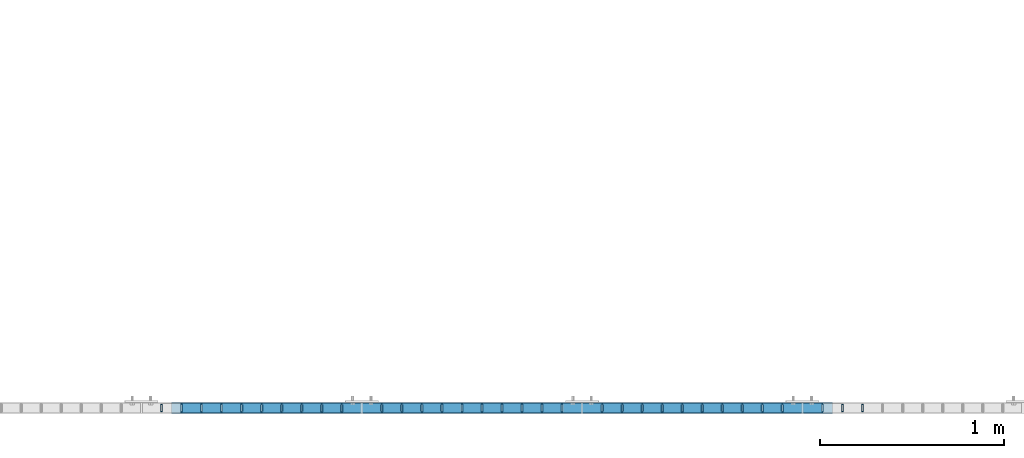
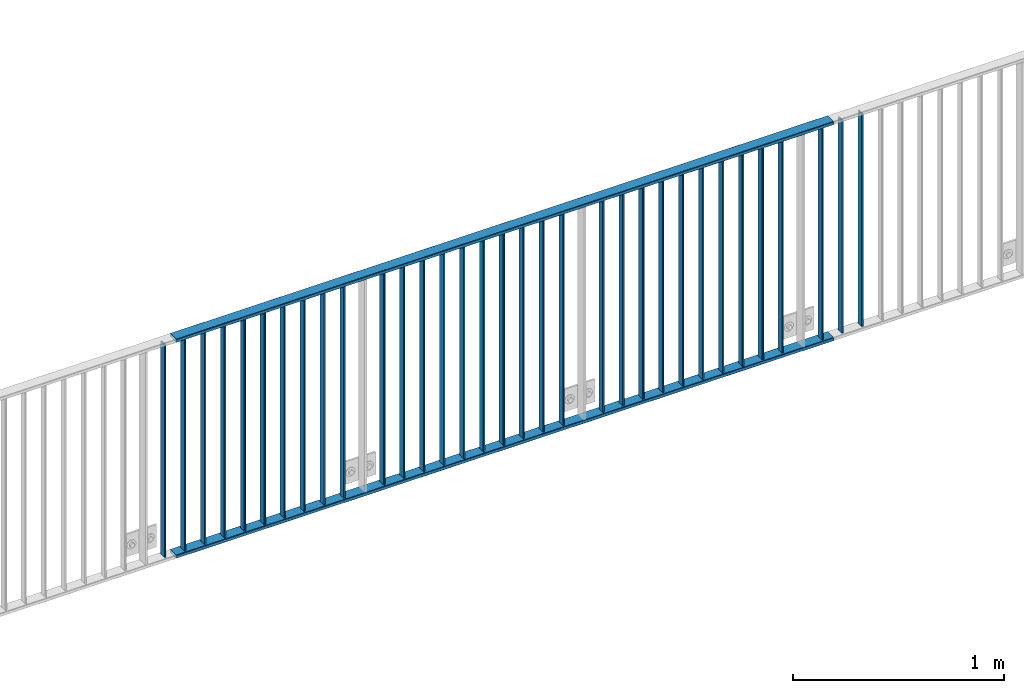
# One storey, part 20 of 156: 35 beams, 3 elements without a shape of their own.
"""IFC2X3 building model written with IfcOpenShell, lengths in millimetres."""

from ifc_helpers import new_model, si_unit, frame, origin_with_axes, origin_2d_with_axis, place, context, subcontext, project, spatial, hollow_rectangle, extrude, clip, halfspace, material, type_object, element, aggregate, save


model = new_model("IFC2X3")

# Units and contexts
model_context = context("Model", 3, precision=1e-05, world=origin_with_axes())
body_context = subcontext(model_context, "Body", "Model", "MODEL_VIEW")
ifc_project = project(units=[si_unit("LENGTHUNIT", "METRE", prefix="MILLI"), si_unit("AREAUNIT", "SQUARE_METRE"), si_unit("VOLUMEUNIT", "CUBIC_METRE"), si_unit("MASSUNIT", "GRAM", prefix="KILO"), si_unit("TIMEUNIT", "SECOND"), si_unit("PLANEANGLEUNIT", "RADIAN"), si_unit("SOLIDANGLEUNIT", "STERADIAN"), si_unit("THERMODYNAMICTEMPERATUREUNIT", "DEGREE_CELSIUS"), si_unit("LUMINOUSINTENSITYUNIT", "LUMEN")], contexts=[model_context])

# Site, building, storey
site_placement = place(None, origin_with_axes())
site = spatial("IfcSite", under=ifc_project, at=site_placement, CompositionType="ELEMENT")
building_placement = place(site_placement, origin_with_axes())
building = spatial("IfcBuilding", under=site, at=building_placement, Name="Undefined", CompositionType="ELEMENT")
storey_placement = place(building_placement, origin_with_axes())
storey = spatial("IfcBuildingStorey", under=building, at=storey_placement, Name="Undefined", CompositionType="ELEMENT", Elevation=0.0)

# Assembly, beams
assembly_1_placement = place(storey_placement, origin_with_axes())
assembly_1 = element("IfcElementAssembly", 1, at=assembly_1_placement, inside=storey, AssemblyPlace="NOTDEFINED", PredefinedType="RIGID_FRAME")
ifc_material = material(Name="STEEL/S235JR")
beam_type_1 = type_object("IfcBeamType", Name="K60/20/2", PredefinedType="NOTDEFINED")
beam_1_placement = place(assembly_1_placement, frame((32363.1399999997, 8480.00209045411, 2740.0), z_axis=(0.0, 1.0, 0.0), x_axis=(1.0, 0.0, 0.0)))
beam_1 = element("IfcBeam", 2, at=beam_1_placement, type_object=beam_type_1, material=ifc_material, ObjectType="K60/20/2", context=body_context, shape_type="SweptSolid", body=[
    extrude(hollow_rectangle(XDim=20.0, YDim=60.0, WallThickness=2.0, InnerFilletRadius=2.0, OuterFilletRadius=4.0, at=origin_2d_with_axis()), frame((3599.89999999999, 0.0, 0.0), z_axis=(-1.0, 0.0, 0.0), x_axis=(0.0, -1.0, 0.0)), (0.0, 0.0, 1.0), 3599.9),
])
beam_2_placement = place(assembly_1_placement, frame((32363.1399999997, 8479.98209032628, 3990.0), z_axis=(0.0, 1.0, 0.0), x_axis=(1.0, 0.0, 0.0)))
beam_2 = element("IfcBeam", 3, at=beam_2_placement, type_object=beam_type_1, material=ifc_material, ObjectType="K60/20/2", context=body_context, shape_type="SweptSolid", body=[
    extrude(hollow_rectangle(XDim=20.0, YDim=60.0, WallThickness=2.0, InnerFilletRadius=2.0, OuterFilletRadius=4.0, at=origin_2d_with_axis()), frame((3599.89999999999, 0.0, 0.0), z_axis=(-1.0, 0.0, 0.0), x_axis=(0.0, -1.0, 0.0)), (0.0, 0.0, 1.0), 3599.9),
])

assembly_2_placement = place(storey_placement, origin_with_axes())
assembly_2 = element("IfcElementAssembly", 4, at=assembly_2_placement, inside=storey, AssemblyPlace="NOTDEFINED", PredefinedType="RIGID_FRAME")
beam_type_2 = type_object("IfcBeamType", Name="K40/10/1.5", PredefinedType="NOTDEFINED")
beam_3_placement = place(assembly_2_placement, frame((36127.269999999, 8480.00209765299, 3980.00000000003), z_axis=(0.0, 1.0, 0.0), x_axis=(0.0, 0.0, -1.0)))
beam_3 = element("IfcBeam", 5, at=beam_3_placement, type_object=beam_type_2, material=ifc_material, ObjectType="K40/10/1.5", context=body_context, shape_type="Clipping", body=[
    clip(extrude(hollow_rectangle(XDim=10.0, YDim=40.0, WallThickness=1.5, InnerFilletRadius=1.5, OuterFilletRadius=3.0, at=origin_2d_with_axis()), frame((1230.0, 0.0, 0.0), z_axis=(-1.0, 0.0, 0.0), x_axis=(0.0, -1.0, 0.0)), (0.0, 0.0, 1.0), 1230.0), halfspace(frame((-6.99999999997453, -4.34248751950508, 47.3810900558092), z_axis=(-1.0, 0.0, 0.0), x_axis=(0.0, 0.7683548141934, -0.640024124159258)), False)),
])
beam_4_placement = place(assembly_2_placement, frame((36018.179999999, 8480.00209765299, 3980.00000000003), z_axis=(0.0, 1.0, 0.0), x_axis=(0.0, 0.0, -1.0)))
beam_4 = element("IfcBeam", 6, at=beam_4_placement, type_object=beam_type_2, material=ifc_material, ObjectType="K40/10/1.5", context=body_context, shape_type="Clipping", body=[
    clip(extrude(hollow_rectangle(XDim=10.0, YDim=40.0, WallThickness=1.5, InnerFilletRadius=1.5, OuterFilletRadius=3.0, at=origin_2d_with_axis()), frame((1230.0, 0.0, 0.0), z_axis=(-1.0, 0.0, 0.0), x_axis=(0.0, -1.0, 0.0)), (0.0, 0.0, 1.0), 1230.0), halfspace(frame((-6.99999999997453, -4.34248751950508, 47.3810900558092), z_axis=(-1.0, 0.0, 0.0), x_axis=(0.0, 0.7683548141934, -0.640024124159258)), False)),
])
aggregate(assembly_2, [beam_3, beam_4])

# Beam
beam_5_placement = place(assembly_1_placement, frame((35909.089999999, 8480.00209765299, 3980.00000000003), z_axis=(0.0, 1.0, 0.0), x_axis=(0.0, 0.0, -1.0)))
beam_5 = element("IfcBeam", 7, at=beam_5_placement, type_object=beam_type_2, material=ifc_material, ObjectType="K40/10/1.5", context=body_context, shape_type="Clipping", body=[
    clip(extrude(hollow_rectangle(XDim=10.0, YDim=40.0, WallThickness=1.5, InnerFilletRadius=1.5, OuterFilletRadius=3.0, at=origin_2d_with_axis()), frame((1230.0, 0.0, 0.0), z_axis=(-1.0, 0.0, 0.0), x_axis=(0.0, -1.0, 0.0)), (0.0, 0.0, 1.0), 1230.0), halfspace(frame((-6.99999999997453, -4.34248751950508, 47.3810900558092), z_axis=(-1.0, 0.0, 0.0), x_axis=(0.0, 0.7683548141934, -0.640024124159258)), False)),
])

beam_6_placement = place(assembly_1_placement, frame((35690.899999999, 8480.00209765299, 3980.00000000003), z_axis=(0.0, 1.0, 0.0), x_axis=(0.0, 0.0, -1.0)))
beam_6 = element("IfcBeam", 8, at=beam_6_placement, type_object=beam_type_2, material=ifc_material, ObjectType="K40/10/1.5", context=body_context, shape_type="Clipping", body=[
    clip(extrude(hollow_rectangle(XDim=10.0, YDim=40.0, WallThickness=1.5, InnerFilletRadius=1.5, OuterFilletRadius=3.0, at=origin_2d_with_axis()), frame((1230.0, 0.0, 0.0), z_axis=(-1.0, 0.0, 0.0), x_axis=(0.0, -1.0, 0.0)), (0.0, 0.0, 1.0), 1230.0), halfspace(frame((-6.99999999997453, -4.34248751950508, 47.3810900558092), z_axis=(-1.0, 0.0, 0.0), x_axis=(0.0, 0.7683548141934, -0.640024124159258)), False)),
])

beam_7_placement = place(assembly_1_placement, frame((35581.809999999, 8480.00209765299, 3980.00000000003), z_axis=(0.0, 1.0, 0.0), x_axis=(0.0, 0.0, -1.0)))
beam_7 = element("IfcBeam", 9, at=beam_7_placement, type_object=beam_type_2, material=ifc_material, ObjectType="K40/10/1.5", context=body_context, shape_type="Clipping", body=[
    clip(extrude(hollow_rectangle(XDim=10.0, YDim=40.0, WallThickness=1.5, InnerFilletRadius=1.5, OuterFilletRadius=3.0, at=origin_2d_with_axis()), frame((1230.0, 0.0, 0.0), z_axis=(-1.0, 0.0, 0.0), x_axis=(0.0, -1.0, 0.0)), (0.0, 0.0, 1.0), 1230.0), halfspace(frame((-6.99999999997453, -4.34248751950508, 47.3810900558092), z_axis=(-1.0, 0.0, 0.0), x_axis=(0.0, 0.7683548141934, -0.640024124159258)), False)),
])

beam_8_placement = place(assembly_1_placement, frame((35472.719999999, 8480.00209765299, 3980.00000000003), z_axis=(0.0, 1.0, 0.0), x_axis=(0.0, 0.0, -1.0)))
beam_8 = element("IfcBeam", 10, at=beam_8_placement, type_object=beam_type_2, material=ifc_material, ObjectType="K40/10/1.5", context=body_context, shape_type="Clipping", body=[
    clip(extrude(hollow_rectangle(XDim=10.0, YDim=40.0, WallThickness=1.5, InnerFilletRadius=1.5, OuterFilletRadius=3.0, at=origin_2d_with_axis()), frame((1230.0, 0.0, 0.0), z_axis=(-1.0, 0.0, 0.0), x_axis=(0.0, -1.0, 0.0)), (0.0, 0.0, 1.0), 1230.0), halfspace(frame((-6.99999999997453, -4.34248751950508, 47.3810900558092), z_axis=(-1.0, 0.0, 0.0), x_axis=(0.0, 0.7683548141934, -0.640024124159258)), False)),
])

beam_9_placement = place(assembly_1_placement, frame((35363.629999999, 8480.00209765299, 3980.00000000003), z_axis=(0.0, 1.0, 0.0), x_axis=(0.0, 0.0, -1.0)))
beam_9 = element("IfcBeam", 11, at=beam_9_placement, type_object=beam_type_2, material=ifc_material, ObjectType="K40/10/1.5", context=body_context, shape_type="Clipping", body=[
    clip(extrude(hollow_rectangle(XDim=10.0, YDim=40.0, WallThickness=1.5, InnerFilletRadius=1.5, OuterFilletRadius=3.0, at=origin_2d_with_axis()), frame((1230.0, 0.0, 0.0), z_axis=(-1.0, 0.0, 0.0), x_axis=(0.0, -1.0, 0.0)), (0.0, 0.0, 1.0), 1230.0), halfspace(frame((-6.99999999997453, -4.34248751950508, 47.3810900558092), z_axis=(-1.0, 0.0, 0.0), x_axis=(0.0, 0.7683548141934, -0.640024124159258)), False)),
])

beam_10_placement = place(assembly_1_placement, frame((35254.539999999, 8480.00209765299, 3980.00000000003), z_axis=(0.0, 1.0, 0.0), x_axis=(0.0, 0.0, -1.0)))
beam_10 = element("IfcBeam", 12, at=beam_10_placement, type_object=beam_type_2, material=ifc_material, ObjectType="K40/10/1.5", context=body_context, shape_type="Clipping", body=[
    clip(extrude(hollow_rectangle(XDim=10.0, YDim=40.0, WallThickness=1.5, InnerFilletRadius=1.5, OuterFilletRadius=3.0, at=origin_2d_with_axis()), frame((1230.0, 0.0, 0.0), z_axis=(-1.0, 0.0, 0.0), x_axis=(0.0, -1.0, 0.0)), (0.0, 0.0, 1.0), 1230.0), halfspace(frame((-6.99999999997453, -4.34248751950508, 47.3810900558092), z_axis=(-1.0, 0.0, 0.0), x_axis=(0.0, 0.7683548141934, -0.640024124159258)), False)),
])

beam_11_placement = place(assembly_1_placement, frame((35145.449999999, 8480.00209765299, 3980.00000000003), z_axis=(0.0, 1.0, 0.0), x_axis=(0.0, 0.0, -1.0)))
beam_11 = element("IfcBeam", 13, at=beam_11_placement, type_object=beam_type_2, material=ifc_material, ObjectType="K40/10/1.5", context=body_context, shape_type="Clipping", body=[
    clip(extrude(hollow_rectangle(XDim=10.0, YDim=40.0, WallThickness=1.5, InnerFilletRadius=1.5, OuterFilletRadius=3.0, at=origin_2d_with_axis()), frame((1230.0, 0.0, 0.0), z_axis=(-1.0, 0.0, 0.0), x_axis=(0.0, -1.0, 0.0)), (0.0, 0.0, 1.0), 1230.0), halfspace(frame((-6.99999999997453, -4.34248751950508, 47.3810900558092), z_axis=(-1.0, 0.0, 0.0), x_axis=(0.0, 0.7683548141934, -0.640024124159258)), False)),
])

beam_12_placement = place(assembly_1_placement, frame((35036.359999999, 8480.00209765299, 3980.00000000003), z_axis=(0.0, 1.0, 0.0), x_axis=(0.0, 0.0, -1.0)))
beam_12 = element("IfcBeam", 14, at=beam_12_placement, type_object=beam_type_2, material=ifc_material, ObjectType="K40/10/1.5", context=body_context, shape_type="Clipping", body=[
    clip(extrude(hollow_rectangle(XDim=10.0, YDim=40.0, WallThickness=1.5, InnerFilletRadius=1.5, OuterFilletRadius=3.0, at=origin_2d_with_axis()), frame((1230.0, 0.0, 0.0), z_axis=(-1.0, 0.0, 0.0), x_axis=(0.0, -1.0, 0.0)), (0.0, 0.0, 1.0), 1230.0), halfspace(frame((-6.99999999997453, -4.34248751950508, 47.3810900558092), z_axis=(-1.0, 0.0, 0.0), x_axis=(0.0, 0.7683548141934, -0.640024124159258)), False)),
])

beam_13_placement = place(assembly_1_placement, frame((34927.269999999, 8480.00209765299, 3980.00000000003), z_axis=(0.0, 1.0, 0.0), x_axis=(0.0, 0.0, -1.0)))
beam_13 = element("IfcBeam", 15, at=beam_13_placement, type_object=beam_type_2, material=ifc_material, ObjectType="K40/10/1.5", context=body_context, shape_type="Clipping", body=[
    clip(extrude(hollow_rectangle(XDim=10.0, YDim=40.0, WallThickness=1.5, InnerFilletRadius=1.5, OuterFilletRadius=3.0, at=origin_2d_with_axis()), frame((1230.0, 0.0, 0.0), z_axis=(-1.0, 0.0, 0.0), x_axis=(0.0, -1.0, 0.0)), (0.0, 0.0, 1.0), 1230.0), halfspace(frame((-6.99999999997453, -4.34248751950508, 47.3810900558092), z_axis=(-1.0, 0.0, 0.0), x_axis=(0.0, 0.7683548141934, -0.640024124159258)), False)),
])

beam_14_placement = place(assembly_1_placement, frame((34818.179999999, 8480.00209765299, 3980.00000000003), z_axis=(0.0, 1.0, 0.0), x_axis=(0.0, 0.0, -1.0)))
beam_14 = element("IfcBeam", 16, at=beam_14_placement, type_object=beam_type_2, material=ifc_material, ObjectType="K40/10/1.5", context=body_context, shape_type="Clipping", body=[
    clip(extrude(hollow_rectangle(XDim=10.0, YDim=40.0, WallThickness=1.5, InnerFilletRadius=1.5, OuterFilletRadius=3.0, at=origin_2d_with_axis()), frame((1230.0, 0.0, 0.0), z_axis=(-1.0, 0.0, 0.0), x_axis=(0.0, -1.0, 0.0)), (0.0, 0.0, 1.0), 1230.0), halfspace(frame((-6.99999999997453, -4.34248751950508, 47.3810900558092), z_axis=(-1.0, 0.0, 0.0), x_axis=(0.0, 0.7683548141934, -0.640024124159258)), False)),
])

beam_15_placement = place(assembly_1_placement, frame((34709.089999999, 8480.00209765299, 3980.00000000003), z_axis=(0.0, 1.0, 0.0), x_axis=(0.0, 0.0, -1.0)))
beam_15 = element("IfcBeam", 17, at=beam_15_placement, type_object=beam_type_2, material=ifc_material, ObjectType="K40/10/1.5", context=body_context, shape_type="Clipping", body=[
    clip(extrude(hollow_rectangle(XDim=10.0, YDim=40.0, WallThickness=1.5, InnerFilletRadius=1.5, OuterFilletRadius=3.0, at=origin_2d_with_axis()), frame((1230.0, 0.0, 0.0), z_axis=(-1.0, 0.0, 0.0), x_axis=(0.0, -1.0, 0.0)), (0.0, 0.0, 1.0), 1230.0), halfspace(frame((-6.99999999997453, -4.34248751950508, 47.3810900558092), z_axis=(-1.0, 0.0, 0.0), x_axis=(0.0, 0.7683548141934, -0.640024124159258)), False)),
])

beam_16_placement = place(assembly_1_placement, frame((34490.899999999, 8480.00209765299, 3980.00000000003), z_axis=(0.0, 1.0, 0.0), x_axis=(0.0, 0.0, -1.0)))
beam_16 = element("IfcBeam", 18, at=beam_16_placement, type_object=beam_type_2, material=ifc_material, ObjectType="K40/10/1.5", context=body_context, shape_type="Clipping", body=[
    clip(extrude(hollow_rectangle(XDim=10.0, YDim=40.0, WallThickness=1.5, InnerFilletRadius=1.5, OuterFilletRadius=3.0, at=origin_2d_with_axis()), frame((1230.0, 0.0, 0.0), z_axis=(-1.0, 0.0, 0.0), x_axis=(0.0, -1.0, 0.0)), (0.0, 0.0, 1.0), 1230.0), halfspace(frame((-6.99999999997453, -4.34248751950508, 47.3810900558092), z_axis=(-1.0, 0.0, 0.0), x_axis=(0.0, 0.7683548141934, -0.640024124159258)), False)),
])

beam_17_placement = place(assembly_1_placement, frame((34381.809999999, 8480.00209765299, 3980.00000000003), z_axis=(0.0, 1.0, 0.0), x_axis=(0.0, 0.0, -1.0)))
beam_17 = element("IfcBeam", 19, at=beam_17_placement, type_object=beam_type_2, material=ifc_material, ObjectType="K40/10/1.5", context=body_context, shape_type="Clipping", body=[
    clip(extrude(hollow_rectangle(XDim=10.0, YDim=40.0, WallThickness=1.5, InnerFilletRadius=1.5, OuterFilletRadius=3.0, at=origin_2d_with_axis()), frame((1230.0, 0.0, 0.0), z_axis=(-1.0, 0.0, 0.0), x_axis=(0.0, -1.0, 0.0)), (0.0, 0.0, 1.0), 1230.0), halfspace(frame((-6.99999999997453, -4.34248751950508, 47.3810900558092), z_axis=(-1.0, 0.0, 0.0), x_axis=(0.0, 0.7683548141934, -0.640024124159258)), False)),
])

beam_18_placement = place(assembly_1_placement, frame((34272.719999999, 8480.00209765299, 3980.00000000003), z_axis=(0.0, 1.0, 0.0), x_axis=(0.0, 0.0, -1.0)))
beam_18 = element("IfcBeam", 20, at=beam_18_placement, type_object=beam_type_2, material=ifc_material, ObjectType="K40/10/1.5", context=body_context, shape_type="Clipping", body=[
    clip(extrude(hollow_rectangle(XDim=10.0, YDim=40.0, WallThickness=1.5, InnerFilletRadius=1.5, OuterFilletRadius=3.0, at=origin_2d_with_axis()), frame((1230.0, 0.0, 0.0), z_axis=(-1.0, 0.0, 0.0), x_axis=(0.0, -1.0, 0.0)), (0.0, 0.0, 1.0), 1230.0), halfspace(frame((-6.99999999997453, -4.34248751950508, 47.3810900558092), z_axis=(-1.0, 0.0, 0.0), x_axis=(0.0, 0.7683548141934, -0.640024124159258)), False)),
])

beam_19_placement = place(assembly_1_placement, frame((34163.629999999, 8480.00209765299, 3980.00000000003), z_axis=(0.0, 1.0, 0.0), x_axis=(0.0, 0.0, -1.0)))
beam_19 = element("IfcBeam", 21, at=beam_19_placement, type_object=beam_type_2, material=ifc_material, ObjectType="K40/10/1.5", context=body_context, shape_type="Clipping", body=[
    clip(extrude(hollow_rectangle(XDim=10.0, YDim=40.0, WallThickness=1.5, InnerFilletRadius=1.5, OuterFilletRadius=3.0, at=origin_2d_with_axis()), frame((1230.0, 0.0, 0.0), z_axis=(-1.0, 0.0, 0.0), x_axis=(0.0, -1.0, 0.0)), (0.0, 0.0, 1.0), 1230.0), halfspace(frame((-6.99999999997453, -4.34248751950508, 47.3810900558092), z_axis=(-1.0, 0.0, 0.0), x_axis=(0.0, 0.7683548141934, -0.640024124159258)), False)),
])

beam_20_placement = place(assembly_1_placement, frame((34054.539999999, 8480.00209765299, 3980.00000000003), z_axis=(0.0, 1.0, 0.0), x_axis=(0.0, 0.0, -1.0)))
beam_20 = element("IfcBeam", 22, at=beam_20_placement, type_object=beam_type_2, material=ifc_material, ObjectType="K40/10/1.5", context=body_context, shape_type="Clipping", body=[
    clip(extrude(hollow_rectangle(XDim=10.0, YDim=40.0, WallThickness=1.5, InnerFilletRadius=1.5, OuterFilletRadius=3.0, at=origin_2d_with_axis()), frame((1230.0, 0.0, 0.0), z_axis=(-1.0, 0.0, 0.0), x_axis=(0.0, -1.0, 0.0)), (0.0, 0.0, 1.0), 1230.0), halfspace(frame((-6.99999999997453, -4.34248751950508, 47.3810900558092), z_axis=(-1.0, 0.0, 0.0), x_axis=(0.0, 0.7683548141934, -0.640024124159258)), False)),
])

beam_21_placement = place(assembly_1_placement, frame((33945.449999999, 8480.00209765299, 3980.00000000003), z_axis=(0.0, 1.0, 0.0), x_axis=(0.0, 0.0, -1.0)))
beam_21 = element("IfcBeam", 23, at=beam_21_placement, type_object=beam_type_2, material=ifc_material, ObjectType="K40/10/1.5", context=body_context, shape_type="Clipping", body=[
    clip(extrude(hollow_rectangle(XDim=10.0, YDim=40.0, WallThickness=1.5, InnerFilletRadius=1.5, OuterFilletRadius=3.0, at=origin_2d_with_axis()), frame((1230.0, 0.0, 0.0), z_axis=(-1.0, 0.0, 0.0), x_axis=(0.0, -1.0, 0.0)), (0.0, 0.0, 1.0), 1230.0), halfspace(frame((-6.99999999997453, -4.34248751950508, 47.3810900558092), z_axis=(-1.0, 0.0, 0.0), x_axis=(0.0, 0.7683548141934, -0.640024124159258)), False)),
])

beam_22_placement = place(assembly_1_placement, frame((33836.359999999, 8480.00209765299, 3980.00000000003), z_axis=(0.0, 1.0, 0.0), x_axis=(0.0, 0.0, -1.0)))
beam_22 = element("IfcBeam", 24, at=beam_22_placement, type_object=beam_type_2, material=ifc_material, ObjectType="K40/10/1.5", context=body_context, shape_type="Clipping", body=[
    clip(extrude(hollow_rectangle(XDim=10.0, YDim=40.0, WallThickness=1.5, InnerFilletRadius=1.5, OuterFilletRadius=3.0, at=origin_2d_with_axis()), frame((1230.0, 0.0, 0.0), z_axis=(-1.0, 0.0, 0.0), x_axis=(0.0, -1.0, 0.0)), (0.0, 0.0, 1.0), 1230.0), halfspace(frame((-6.99999999997453, -4.34248751950508, 47.3810900558092), z_axis=(-1.0, 0.0, 0.0), x_axis=(0.0, 0.7683548141934, -0.640024124159258)), False)),
])

beam_23_placement = place(assembly_1_placement, frame((33727.269999999, 8480.00209765299, 3980.00000000003), z_axis=(0.0, 1.0, 0.0), x_axis=(0.0, 0.0, -1.0)))
beam_23 = element("IfcBeam", 25, at=beam_23_placement, type_object=beam_type_2, material=ifc_material, ObjectType="K40/10/1.5", context=body_context, shape_type="Clipping", body=[
    clip(extrude(hollow_rectangle(XDim=10.0, YDim=40.0, WallThickness=1.5, InnerFilletRadius=1.5, OuterFilletRadius=3.0, at=origin_2d_with_axis()), frame((1230.0, 0.0, 0.0), z_axis=(-1.0, 0.0, 0.0), x_axis=(0.0, -1.0, 0.0)), (0.0, 0.0, 1.0), 1230.0), halfspace(frame((-6.99999999997453, -4.34248751950508, 47.3810900558092), z_axis=(-1.0, 0.0, 0.0), x_axis=(0.0, 0.7683548141934, -0.640024124159258)), False)),
])

beam_24_placement = place(assembly_1_placement, frame((33618.179999999, 8480.00209765299, 3980.00000000003), z_axis=(0.0, 1.0, 0.0), x_axis=(0.0, 0.0, -1.0)))
beam_24 = element("IfcBeam", 26, at=beam_24_placement, type_object=beam_type_2, material=ifc_material, ObjectType="K40/10/1.5", context=body_context, shape_type="Clipping", body=[
    clip(extrude(hollow_rectangle(XDim=10.0, YDim=40.0, WallThickness=1.5, InnerFilletRadius=1.5, OuterFilletRadius=3.0, at=origin_2d_with_axis()), frame((1230.0, 0.0, 0.0), z_axis=(-1.0, 0.0, 0.0), x_axis=(0.0, -1.0, 0.0)), (0.0, 0.0, 1.0), 1230.0), halfspace(frame((-6.99999999997453, -4.34248751950508, 47.3810900558092), z_axis=(-1.0, 0.0, 0.0), x_axis=(0.0, 0.7683548141934, -0.640024124159258)), False)),
])

beam_25_placement = place(assembly_1_placement, frame((33509.089999999, 8480.00209765299, 3980.00000000003), z_axis=(0.0, 1.0, 0.0), x_axis=(0.0, 0.0, -1.0)))
beam_25 = element("IfcBeam", 27, at=beam_25_placement, type_object=beam_type_2, material=ifc_material, ObjectType="K40/10/1.5", context=body_context, shape_type="Clipping", body=[
    clip(extrude(hollow_rectangle(XDim=10.0, YDim=40.0, WallThickness=1.5, InnerFilletRadius=1.5, OuterFilletRadius=3.0, at=origin_2d_with_axis()), frame((1230.0, 0.0, 0.0), z_axis=(-1.0, 0.0, 0.0), x_axis=(0.0, -1.0, 0.0)), (0.0, 0.0, 1.0), 1230.0), halfspace(frame((-6.99999999997453, -4.34248751950508, 47.3810900558092), z_axis=(-1.0, 0.0, 0.0), x_axis=(0.0, 0.7683548141934, -0.640024124159258)), False)),
])

beam_26_placement = place(assembly_1_placement, frame((33290.899999999, 8480.00209765299, 3980.00000000003), z_axis=(0.0, 1.0, 0.0), x_axis=(0.0, 0.0, -1.0)))
beam_26 = element("IfcBeam", 28, at=beam_26_placement, type_object=beam_type_2, material=ifc_material, ObjectType="K40/10/1.5", context=body_context, shape_type="Clipping", body=[
    clip(extrude(hollow_rectangle(XDim=10.0, YDim=40.0, WallThickness=1.5, InnerFilletRadius=1.5, OuterFilletRadius=3.0, at=origin_2d_with_axis()), frame((1230.0, 0.0, 0.0), z_axis=(-1.0, 0.0, 0.0), x_axis=(0.0, -1.0, 0.0)), (0.0, 0.0, 1.0), 1230.0), halfspace(frame((-6.99999999997453, -4.34248751950508, 47.3810900558092), z_axis=(-1.0, 0.0, 0.0), x_axis=(0.0, 0.7683548141934, -0.640024124159258)), False)),
])

beam_27_placement = place(assembly_1_placement, frame((33181.809999999, 8480.00209765299, 3980.00000000003), z_axis=(0.0, 1.0, 0.0), x_axis=(0.0, 0.0, -1.0)))
beam_27 = element("IfcBeam", 29, at=beam_27_placement, type_object=beam_type_2, material=ifc_material, ObjectType="K40/10/1.5", context=body_context, shape_type="Clipping", body=[
    clip(extrude(hollow_rectangle(XDim=10.0, YDim=40.0, WallThickness=1.5, InnerFilletRadius=1.5, OuterFilletRadius=3.0, at=origin_2d_with_axis()), frame((1230.0, 0.0, 0.0), z_axis=(-1.0, 0.0, 0.0), x_axis=(0.0, -1.0, 0.0)), (0.0, 0.0, 1.0), 1230.0), halfspace(frame((-6.99999999997453, -4.34248751950508, 47.3810900558092), z_axis=(-1.0, 0.0, 0.0), x_axis=(0.0, 0.7683548141934, -0.640024124159258)), False)),
])

beam_28_placement = place(assembly_1_placement, frame((33072.719999999, 8480.00209765299, 3980.00000000003), z_axis=(0.0, 1.0, 0.0), x_axis=(0.0, 0.0, -1.0)))
beam_28 = element("IfcBeam", 30, at=beam_28_placement, type_object=beam_type_2, material=ifc_material, ObjectType="K40/10/1.5", context=body_context, shape_type="Clipping", body=[
    clip(extrude(hollow_rectangle(XDim=10.0, YDim=40.0, WallThickness=1.5, InnerFilletRadius=1.5, OuterFilletRadius=3.0, at=origin_2d_with_axis()), frame((1230.0, 0.0, 0.0), z_axis=(-1.0, 0.0, 0.0), x_axis=(0.0, -1.0, 0.0)), (0.0, 0.0, 1.0), 1230.0), halfspace(frame((-6.99999999997453, -4.34248751950508, 47.3810900558092), z_axis=(-1.0, 0.0, 0.0), x_axis=(0.0, 0.7683548141934, -0.640024124159258)), False)),
])

beam_29_placement = place(assembly_1_placement, frame((32963.629999999, 8480.00209765299, 3980.00000000003), z_axis=(0.0, 1.0, 0.0), x_axis=(0.0, 0.0, -1.0)))
beam_29 = element("IfcBeam", 31, at=beam_29_placement, type_object=beam_type_2, material=ifc_material, ObjectType="K40/10/1.5", context=body_context, shape_type="Clipping", body=[
    clip(extrude(hollow_rectangle(XDim=10.0, YDim=40.0, WallThickness=1.5, InnerFilletRadius=1.5, OuterFilletRadius=3.0, at=origin_2d_with_axis()), frame((1230.0, 0.0, 0.0), z_axis=(-1.0, 0.0, 0.0), x_axis=(0.0, -1.0, 0.0)), (0.0, 0.0, 1.0), 1230.0), halfspace(frame((-6.99999999997453, -4.34248751950508, 47.3810900558092), z_axis=(-1.0, 0.0, 0.0), x_axis=(0.0, 0.7683548141934, -0.640024124159258)), False)),
])

beam_30_placement = place(assembly_1_placement, frame((32854.539999999, 8480.00209765299, 3980.00000000003), z_axis=(0.0, 1.0, 0.0), x_axis=(0.0, 0.0, -1.0)))
beam_30 = element("IfcBeam", 32, at=beam_30_placement, type_object=beam_type_2, material=ifc_material, ObjectType="K40/10/1.5", context=body_context, shape_type="Clipping", body=[
    clip(extrude(hollow_rectangle(XDim=10.0, YDim=40.0, WallThickness=1.5, InnerFilletRadius=1.5, OuterFilletRadius=3.0, at=origin_2d_with_axis()), frame((1230.0, 0.0, 0.0), z_axis=(-1.0, 0.0, 0.0), x_axis=(0.0, -1.0, 0.0)), (0.0, 0.0, 1.0), 1230.0), halfspace(frame((-6.99999999997453, -4.34248751950508, 47.3810900558092), z_axis=(-1.0, 0.0, 0.0), x_axis=(0.0, 0.7683548141934, -0.640024124159258)), False)),
])

beam_31_placement = place(assembly_1_placement, frame((32745.449999999, 8480.00209765299, 3980.00000000003), z_axis=(0.0, 1.0, 0.0), x_axis=(0.0, 0.0, -1.0)))
beam_31 = element("IfcBeam", 33, at=beam_31_placement, type_object=beam_type_2, material=ifc_material, ObjectType="K40/10/1.5", context=body_context, shape_type="Clipping", body=[
    clip(extrude(hollow_rectangle(XDim=10.0, YDim=40.0, WallThickness=1.5, InnerFilletRadius=1.5, OuterFilletRadius=3.0, at=origin_2d_with_axis()), frame((1230.0, 0.0, 0.0), z_axis=(-1.0, 0.0, 0.0), x_axis=(0.0, -1.0, 0.0)), (0.0, 0.0, 1.0), 1230.0), halfspace(frame((-6.99999999997453, -4.34248751950508, 47.3810900558092), z_axis=(-1.0, 0.0, 0.0), x_axis=(0.0, 0.7683548141934, -0.640024124159258)), False)),
])

beam_32_placement = place(assembly_1_placement, frame((32636.359999999, 8480.00209765299, 3980.00000000003), z_axis=(0.0, 1.0, 0.0), x_axis=(0.0, 0.0, -1.0)))
beam_32 = element("IfcBeam", 34, at=beam_32_placement, type_object=beam_type_2, material=ifc_material, ObjectType="K40/10/1.5", context=body_context, shape_type="Clipping", body=[
    clip(extrude(hollow_rectangle(XDim=10.0, YDim=40.0, WallThickness=1.5, InnerFilletRadius=1.5, OuterFilletRadius=3.0, at=origin_2d_with_axis()), frame((1230.0, 0.0, 0.0), z_axis=(-1.0, 0.0, 0.0), x_axis=(0.0, -1.0, 0.0)), (0.0, 0.0, 1.0), 1230.0), halfspace(frame((-6.99999999997453, -4.34248751950508, 47.3810900558092), z_axis=(-1.0, 0.0, 0.0), x_axis=(0.0, 0.7683548141934, -0.640024124159258)), False)),
])

beam_33_placement = place(assembly_1_placement, frame((32527.269999999, 8480.00209765299, 3980.00000000003), z_axis=(0.0, 1.0, 0.0), x_axis=(0.0, 0.0, -1.0)))
beam_33 = element("IfcBeam", 35, at=beam_33_placement, type_object=beam_type_2, material=ifc_material, ObjectType="K40/10/1.5", context=body_context, shape_type="Clipping", body=[
    clip(extrude(hollow_rectangle(XDim=10.0, YDim=40.0, WallThickness=1.5, InnerFilletRadius=1.5, OuterFilletRadius=3.0, at=origin_2d_with_axis()), frame((1230.0, 0.0, 0.0), z_axis=(-1.0, 0.0, 0.0), x_axis=(0.0, -1.0, 0.0)), (0.0, 0.0, 1.0), 1230.0), halfspace(frame((-6.99999999997453, -4.34248751950508, 47.3810900558092), z_axis=(-1.0, 0.0, 0.0), x_axis=(0.0, 0.7683548141934, -0.640024124159258)), False)),
])

beam_34_placement = place(assembly_1_placement, frame((32418.179999999, 8480.00209765299, 3980.00000000003), z_axis=(0.0, 1.0, 0.0), x_axis=(0.0, 0.0, -1.0)))
beam_34 = element("IfcBeam", 36, at=beam_34_placement, type_object=beam_type_2, material=ifc_material, ObjectType="K40/10/1.5", context=body_context, shape_type="Clipping", body=[
    clip(extrude(hollow_rectangle(XDim=10.0, YDim=40.0, WallThickness=1.5, InnerFilletRadius=1.5, OuterFilletRadius=3.0, at=origin_2d_with_axis()), frame((1230.0, 0.0, 0.0), z_axis=(-1.0, 0.0, 0.0), x_axis=(0.0, -1.0, 0.0)), (0.0, 0.0, 1.0), 1230.0), halfspace(frame((-6.99999999997453, -4.34248751950508, 47.3810900558092), z_axis=(-1.0, 0.0, 0.0), x_axis=(0.0, 0.7683548141934, -0.640024124159258)), False)),
])

aggregate(assembly_1, [beam_1, beam_2, beam_5, beam_6, beam_7, beam_8, beam_9, beam_10, beam_11, beam_12, beam_13, beam_14, beam_15, beam_16, beam_17, beam_18, beam_19, beam_20, beam_21, beam_22, beam_23, beam_24, beam_25, beam_26, beam_27, beam_28, beam_29, beam_30, beam_31, beam_32, beam_33, beam_34])

# Assembly, beam
assembly_3_placement = place(storey_placement, origin_with_axes())
assembly_3 = element("IfcElementAssembly", 37, at=assembly_3_placement, inside=storey, AssemblyPlace="NOTDEFINED", PredefinedType="RIGID_FRAME")
beam_35_placement = place(assembly_3_placement, frame((32309.089999999, 8480.00209765299, 3980.00000000003), z_axis=(0.0, 1.0, 0.0), x_axis=(0.0, 0.0, -1.0)))
beam_35 = element("IfcBeam", 38, at=beam_35_placement, type_object=beam_type_2, material=ifc_material, ObjectType="K40/10/1.5", context=body_context, shape_type="Clipping", body=[
    clip(extrude(hollow_rectangle(XDim=10.0, YDim=40.0, WallThickness=1.5, InnerFilletRadius=1.5, OuterFilletRadius=3.0, at=origin_2d_with_axis()), frame((1230.0, 0.0, 0.0), z_axis=(-1.0, 0.0, 0.0), x_axis=(0.0, -1.0, 0.0)), (0.0, 0.0, 1.0), 1230.0), halfspace(frame((-6.99999999997453, -4.34248751950508, 47.3810900558092), z_axis=(-1.0, 0.0, 0.0), x_axis=(0.0, 0.7683548141934, -0.640024124159258)), False)),
])
aggregate(assembly_3, [beam_35])

save(model, "model.ifc")
